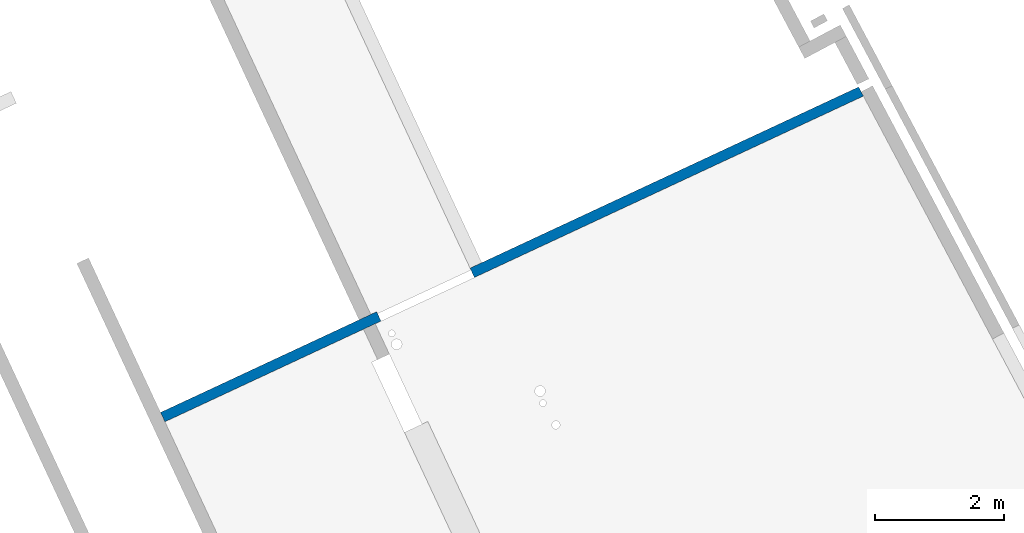
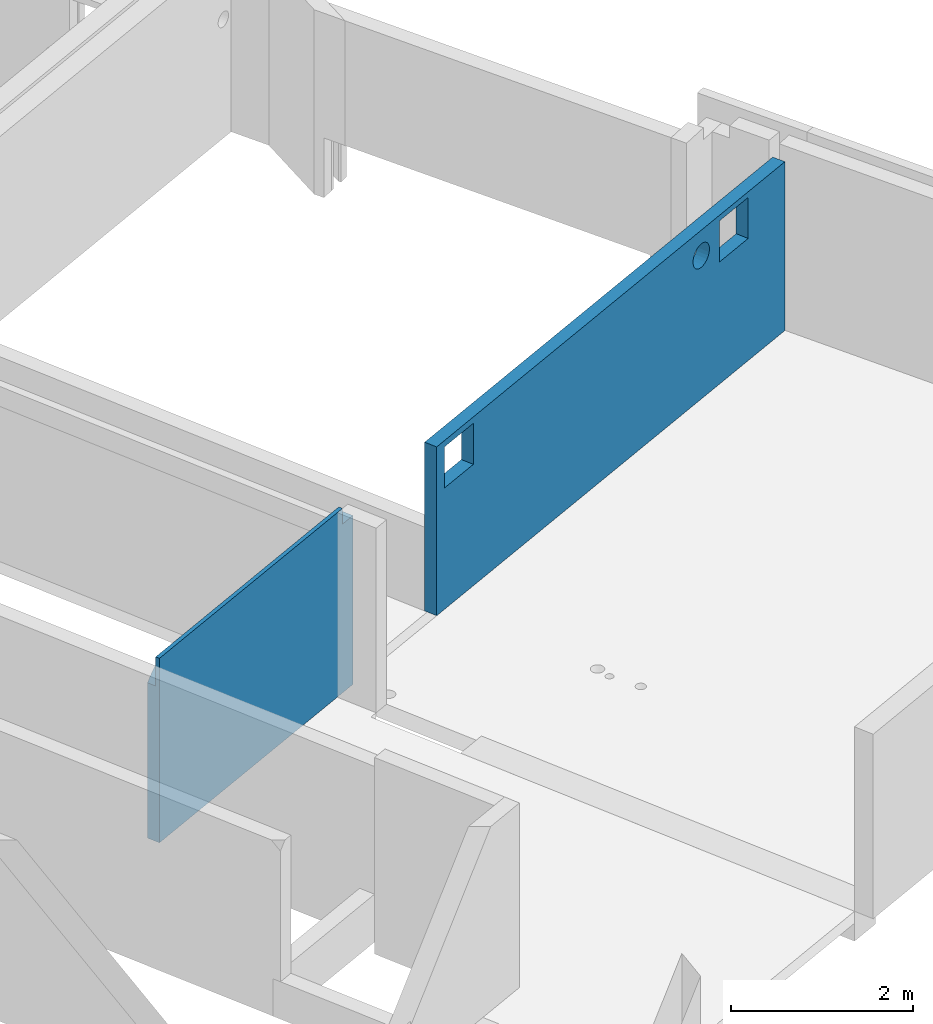
# One storey, part 8 of 13: 1 wall.
"""IFC2X3 building model written with IfcOpenShell, lengths in metres."""

from ifc_helpers import new_model, entity, si_unit, converted_unit, derived_unit, direction, frame, origin, place, context, subcontext, project, spatial, faceted_brep, material, layer, layer_set, type_object, element, save


model = new_model("IFC2X3")

# Units and contexts
model_context = context("Model", 3, precision=1e-05, world=origin(), true_north=direction((6.12303176911189e-17, 1.0)))
body_context = subcontext(model_context, "Body", "Model", "MODEL_VIEW")
ifc_project = project(units=[si_unit("LENGTHUNIT", "METRE"), si_unit("AREAUNIT", "SQUARE_METRE"), si_unit("VOLUMEUNIT", "CUBIC_METRE"), converted_unit("PLANEANGLEUNIT", "DEGREE", entity("IfcRatioMeasure", 0.0174532925199433), si_unit("PLANEANGLEUNIT", "RADIAN"), dimensions=[0, 0, 0, 0, 0, 0, 0]), si_unit("MASSUNIT", "GRAM", prefix="KILO"), derived_unit("MASSDENSITYUNIT", [(si_unit("MASSUNIT", "GRAM", prefix="KILO"), 1), (si_unit("LENGTHUNIT", "METRE"), -3)]), si_unit("TIMEUNIT", "SECOND"), si_unit("FREQUENCYUNIT", "HERTZ"), si_unit("THERMODYNAMICTEMPERATUREUNIT", "DEGREE_CELSIUS"), derived_unit("THERMALTRANSMITTANCEUNIT", [(si_unit("MASSUNIT", "GRAM", prefix="KILO"), 1), (si_unit("THERMODYNAMICTEMPERATUREUNIT", "KELVIN"), -1), (si_unit("TIMEUNIT", "SECOND"), -3)]), derived_unit("VOLUMETRICFLOWRATEUNIT", [(si_unit("LENGTHUNIT", "METRE"), 3), (si_unit("TIMEUNIT", "SECOND"), -1)]), si_unit("ELECTRICCURRENTUNIT", "AMPERE"), si_unit("ELECTRICVOLTAGEUNIT", "VOLT"), si_unit("POWERUNIT", "WATT"), si_unit("FORCEUNIT", "NEWTON", prefix="KILO"), si_unit("ILLUMINANCEUNIT", "LUX"), si_unit("LUMINOUSFLUXUNIT", "LUMEN"), si_unit("LUMINOUSINTENSITYUNIT", "CANDELA"), derived_unit("USERDEFINED", [(si_unit("MASSUNIT", "GRAM", prefix="KILO"), -1), (si_unit("LENGTHUNIT", "METRE"), -2), (si_unit("TIMEUNIT", "SECOND"), 3), (si_unit("LUMINOUSFLUXUNIT", "LUMEN"), 1)]), derived_unit("LINEARVELOCITYUNIT", [(si_unit("LENGTHUNIT", "METRE"), 1), (si_unit("TIMEUNIT", "SECOND"), -1)]), si_unit("PRESSUREUNIT", "PASCAL"), derived_unit("USERDEFINED", [(si_unit("LENGTHUNIT", "METRE"), -2), (si_unit("MASSUNIT", "GRAM", prefix="KILO"), 1), (si_unit("TIMEUNIT", "SECOND"), -2)])], contexts=[model_context])

# Site, building, storey
site_placement = place(None, frame((5.36960000000003, 43.3158000000006, 0.0), z_axis=(0.0, 0.0, 1.0), x_axis=(-0.422618261740703, 0.906307787036648, 0.0)))
site = spatial("IfcSite", under=ifc_project, at=site_placement, CompositionType="ELEMENT")
building_placement = place(site_placement, origin())
building = spatial("IfcBuilding", under=site, at=building_placement, CompositionType="ELEMENT")
storey_placement = place(building_placement, frame((0.0, 0.0, 2.56)))
storey = spatial("IfcBuildingStorey", under=building, at=storey_placement, CompositionType="ELEMENT", Elevation=2.56)

# Wall
ifc_material = material(Name="C30/37 XC1")
ifc_layer = layer(ifc_material, 0.16)
ifc_layer_set = layer_set([ifc_layer])
wall_type = type_object("IfcWallType", PredefinedType="NOTDEFINED", material=ifc_layer_set)
wall_placement = place(storey_placement, frame((13.0006608482375, 13.1325037603587, 0.0), z_axis=(0.0, 0.0, 1.0), x_axis=(0.0, -1.0, 0.0)))
element("IfcWall", 1, at=wall_placement, inside=storey, type_object=wall_type, Name="XS1", context=body_context, shape_type="Brep", body=[
    faceted_brep([(0.0, 0.0799999999999993, 0.0), (3.69997791133383, 0.0799999999999983, 0.0), (3.69997791133383, -0.0800000000000022, 0.0), (0.0, -0.0799999999999989, 0.0), (0.0, 0.0799999999999993, 2.07800573622916), (0.0540647674175499, 0.0799999999999998, 2.14298123226232), (0.116506424114537, 0.0800000000000003, 2.19995362618784), (0.186151946035246, 0.0800000000000008, 2.24785263909063), (0.261692977877982, 0.0799999999999992, 2.28577844387845), (0.341710411754961, 0.0799999999999999, 2.31301856936297), (0.424701046441563, 0.0800000000000005, 2.32906128468751), (0.509105826396406, 0.079999999999999, 2.3336052126627), (0.593339130056231, 0.0799999999999997, 2.32656499141468), (0.67581855719798, 0.0800000000000004, 2.30807287798657), (0.754994655785037, 0.080000000000001, 2.27847626376802), (0.829380029851418, 0.0799999999999994, 2.23833114842788), (0.897577281605511, 0.0799999999999999, 2.1883916949481), (0.958305262835159, 0.0800000000000004, 2.12959606197727), (1.01042314245731, 0.0800000000000008, 2.0630487796559), (1.05295183808109, 0.079999999999999, 1.99000000000005), (1.14700398459006, 0.0799999999999998, 1.99000000000006), (1.19017387657793, 0.0800000000000001, 2.06399261157951), (1.24318059167475, 0.0800000000000005, 2.13128922588688), (1.30500134927377, 0.080000000000001, 2.19059133438627), (1.37444329915118, 0.0799999999999994, 2.24075468495036), (1.4501665378721, 0.08, 2.28081136055138), (1.5307099626328, 0.0800000000000006, 2.30998845551315), (1.61451946368142, 0.0799999999999991, 2.32772298895986), (1.69997791133585, 0.0799999999999998, 2.33367276770247), (1.78543635899028, 0.0800000000000005, 2.32772298895985), (1.8692458600389, 0.079999999999999, 2.30998845551314), (1.9497892847996, 0.0799999999999996, 2.28081136055138), (2.02551252352052, 0.0800000000000002, 2.24075468495035), (2.09495447339793, 0.0800000000000007, 2.19059133438626), (2.15677523099694, 0.0799999999999991, 2.13128922588687), (2.20978194609376, 0.0799999999999995, 2.06399261157949), (2.25295183808165, 0.0799999999999998, 1.99000000000006), (2.3470039845898, 0.0800000000000006, 1.99000000000006), (2.39017387657767, 0.0800000000000009, 2.06399261157951), (2.4431805916745, 0.0799999999999992, 2.13128922588688), (2.50500134927352, 0.0799999999999996, 2.19059133438628), (2.57444329915092, 0.0800000000000002, 2.24075468495036), (2.65016653787184, 0.0800000000000008, 2.28081136055139), (2.73070996263254, 0.0799999999999993, 2.30998845551315), (2.81451946368116, 0.0799999999999999, 2.32772298895986), (2.8999779113356, 0.0800000000000006, 2.33367276770248), (2.98543635899002, 0.0799999999999991, 2.32772298895986), (3.06924586003864, 0.0799999999999998, 2.30998845551315), (3.14978928479935, 0.0800000000000004, 2.28081136055138), (3.22551252352026, 0.080000000000001, 2.24075468495035), (3.29495447339767, 0.0799999999999994, 2.19059133438627), (3.35677523099669, 0.0799999999999999, 2.13128922588687), (3.40978194609351, 0.0800000000000003, 2.0639926115795), (3.4529518380814, 0.0800000000000006, 1.99000000000006), (3.49997791133412, 0.080000000000001, 1.99000000000006), (3.49997791133412, 0.080000000000001, 2.26), (3.59997791133629, 0.0799999999999996, 2.26), (3.69997791133383, 0.0800000000000004, 2.26), (3.39997791133411, -0.0800000000000002, 2.47), (0.0, -0.0800000000000011, 2.47), (0.0, -0.0800000000000011, 2.26), (3.69997791133383, -0.08, 2.26), (3.59997791133411, -0.0800000000000008, 2.26), (3.49997791133869, -0.0799999999999994, 2.26), (3.49997791133869, -0.0799999999999994, 2.47), (3.49997791133412, -0.0300000000002209, 2.47), (0.0, -0.0300000000002139, 2.47), (0.0, -0.0300000000002139, 2.07800573622919), (0.509102556304195, -0.0300000000002164, 2.33360526106011), (0.42469795081063, -0.0300000000002149, 2.3290609039723), (0.341707651595475, -0.0300000000002155, 2.31301783646269), (0.261690685984044, -0.0300000000002161, 2.28577748376197), (0.186150215713108, -0.0300000000002146, 2.24785161623326), (0.116505300126185, -0.0300000000002151, 2.1999527337884), (0.0540642395365872, -0.0300000000002156, 2.14298067972582), (3.49997791133412, -0.0300000000002209, 2.26), (3.49997791133412, -0.0300000000002209, 1.99000000000006), (3.4529518380814, -0.0300000000002213, 1.99000000000006), (3.40978194609353, -0.0300000000002216, 2.06399261157951), (3.35677523099671, -0.030000000000222, 2.13128922588688), (3.29495447339769, -0.0300000000002203, 2.19059133438628), (3.22551252352028, -0.0300000000002209, 2.24075468495036), (3.14978928479936, -0.0300000000002215, 2.28081136055139), (3.06924586003866, -0.03000000000022, 2.30998845551315), (2.98543635899004, -0.0300000000002206, 2.32772298895986), (2.89997791133561, -0.0300000000002213, 2.33367276770248), (2.81451946368118, -0.0300000000002198, 2.32772298895986), (2.73070996263256, -0.0300000000002205, 2.30998845551315), (2.65016653787186, -0.0300000000002211, 2.28081136055138), (2.57444329915094, -0.0300000000002195, 2.24075468495035), (2.50500134927354, -0.0300000000002201, 2.19059133438627), (2.44318059167451, -0.0300000000002206, 2.13128922588688), (2.39017387657769, -0.0300000000002188, 2.0639926115795), (2.34700398458983, -0.0300000000002192, 1.99000000000006), (2.25295183808165, -0.0300000000002199, 1.99000000000006), (2.20978194609378, -0.0300000000002202, 2.0639926115795), (2.15677523099696, -0.0300000000002185, 2.13128922588688), (2.09495447339794, -0.030000000000219, 2.19059133438627), (2.02551252352054, -0.0300000000002195, 2.24075468495035), (1.94978928479962, -0.030000000000218, 2.28081136055138), (1.86924586003891, -0.0300000000002186, 2.30998845551315), (1.7854363589903, -0.0300000000002193, 2.32772298895986), (1.69997791133587, -0.0300000000002178, 2.33367276770247), (1.61451946368143, -0.0300000000002184, 2.32772298895985), (1.53070996263282, -0.0300000000002169, 2.30998845551315), (1.45016653787211, -0.0300000000002176, 2.28081136055138), (1.3744432991512, -0.0300000000002182, 2.24075468495035), (1.30500134927379, -0.0300000000002166, 2.19059133438627), (1.24318059167477, -0.0300000000002171, 2.13128922588687), (1.19017387657795, -0.0300000000002175, 2.0639926115795), (1.14700398459008, -0.0300000000002178, 1.99000000000005), (1.05295183808109, -0.0300000000002164, 1.99000000000005), (1.01042260784432, -0.0300000000002167, 2.06304956816565), (0.958304179887242, -0.0300000000002171, 2.12959726485254), (0.897575586120023, -0.0300000000002176, 2.18839312490938), (0.829377761928949, -0.030000000000216, 2.23833258130818), (0.754991909372078, -0.0300000000002166, 2.27847751107533), (0.675815467961812, -0.0300000000002172, 2.3080737969531), (0.593335861735365, -0.0300000000002157, 2.32656549195455)], [[[0, 1, 2, 3]], [[1, 0, 4, 5, 6, 7, 8, 9, 10, 11, 12, 13, 14, 15, 16, 17, 18, 19, 20, 21, 22, 23, 24, 25, 26, 27, 28, 29, 30, 31, 32, 33, 34, 35, 36, 37, 38, 39, 40, 41, 42, 43, 44, 45, 46, 47, 48, 49, 50, 51, 52, 53, 54, 55, 56, 57]], [[58, 59, 60, 3, 2, 61, 62, 63, 64]], [[58, 64, 65, 66, 59]], [[67, 4, 0, 3, 60, 59, 66]], [[68, 69, 70, 71, 72, 73, 74, 67, 66, 65, 75, 76, 77, 78, 79, 80, 81, 82, 83, 84, 85, 86, 87, 88, 89, 90, 91, 92, 93, 94, 95, 96, 97, 98, 99, 100, 101, 102, 103, 104, 105, 106, 107, 108, 109, 110, 111, 112, 113, 114, 115, 116, 117, 118]], [[76, 75, 55, 54]], [[74, 73, 5]], [[74, 4, 67]], [[72, 6, 73]], [[8, 71, 70]], [[9, 70, 69]], [[7, 72, 71]], [[68, 10, 69]], [[7, 6, 72]], [[5, 4, 74]], [[6, 5, 73]], [[9, 8, 70]], [[11, 10, 68]], [[9, 69, 10]], [[7, 71, 8]], [[68, 118, 11]], [[12, 118, 117]], [[13, 117, 116]], [[115, 14, 116]], [[16, 114, 113]], [[113, 112, 17]], [[114, 15, 115]], [[18, 112, 111]], [[13, 12, 117]], [[15, 14, 115]], [[13, 116, 14]], [[17, 16, 113]], [[19, 18, 111]], [[17, 112, 18]], [[15, 114, 16]], [[118, 12, 11]], [[20, 19, 111, 110]], [[37, 36, 94, 93]], [[54, 53, 77, 76]], [[23, 22, 108, 107]], [[108, 22, 21, 109]], [[106, 24, 23, 107]], [[104, 26, 25, 105]], [[26, 104, 103, 27]], [[25, 24, 106, 105]], [[102, 28, 27, 103]], [[109, 21, 20, 110]], [[29, 101, 100, 30]], [[30, 100, 99, 31]], [[98, 32, 31, 99]], [[33, 97, 96, 34]], [[96, 95, 35, 34]], [[97, 33, 32, 98]], [[35, 95, 94, 36]], [[29, 28, 102, 101]], [[40, 39, 91, 90]], [[91, 39, 38, 92]], [[89, 41, 40, 90]], [[87, 43, 42, 88]], [[43, 87, 86, 44]], [[42, 41, 89, 88]], [[85, 45, 44, 86]], [[92, 38, 37, 93]], [[46, 84, 83, 47]], [[47, 83, 82, 48]], [[81, 49, 48, 82]], [[50, 80, 79, 51]], [[79, 78, 52, 51]], [[80, 50, 49, 81]], [[52, 78, 77, 53]], [[46, 45, 85, 84]], [[75, 63, 62, 61, 57, 56, 55]], [[65, 64, 63, 75]], [[57, 61, 2, 1]]]),
    faceted_brep([(11.9530510296318, 0.0799999999999985, 2.26), (5.29997791133383, 0.0800000000000001, 2.26), (5.29997791133383, -0.0800000000000004, 2.26), (11.9614016144943, -0.0799999999999954, 2.26), (5.29997791133383, -0.0800000000000004, 0.0), (6.00165913325264, -0.0800000000000013, 1.6249998993897), (5.45165913325264, -0.0800000000000013, 1.6249998993897), (10.2476644481492, -0.0800000000000003, 1.80863068196312), (10.280283766186, -0.08, 1.78360099890395), (11.9614016144943, -0.0799999999999997, 0.0), (10.3182697665824, -0.0799999999999997, 1.76786668235947), (10.7056146308703, -0.080000000000001, 1.63500050947051), (11.2556146308703, -0.080000000000001, 1.63500050947051), (10.7056146308703, -0.080000000000001, 2.18500050947051), (11.2556146308703, -0.080000000000001, 2.18500050947051), (10.359033766186, -0.0800000000000016, 1.7625), (10.516533766186, -0.0800000000000003, 1.92), (10.5111670838266, -0.0800000000000004, 1.87923600039635), (10.4954327672821, -0.0800000000000005, 1.84125), (10.4704030842229, -0.0800000000000007, 1.80863068196311), (10.437783766186, -0.0800000000000009, 1.78360099890395), (10.3997977657897, -0.0800000000000012, 1.76786668235947), (10.22263476509, -0.0800000000000005, 1.84125), (10.2069004485455, -0.0800000000000006, 1.87923600039635), (10.201533766186, -0.0800000000000006, 1.92), (6.00165913325264, -0.0800000000000013, 2.1749998993897), (10.2069004485455, -0.0800000000000006, 1.96076399960364), (10.22263476509, -0.0800000000000005, 1.99875), (10.2476644481492, -0.0800000000000003, 2.03136931803688), (10.280283766186, -0.08, 2.05639900109605), (10.3182697665824, -0.0799999999999997, 2.07213331764053), (10.359033766186, -0.0800000000000016, 2.0775), (10.3997977657897, -0.0800000000000012, 2.07213331764052), (10.437783766186, -0.0800000000000009, 2.05639900109605), (10.4704030842229, -0.0800000000000007, 2.03136931803688), (10.4954327672821, -0.0800000000000005, 1.99875), (10.5111670838266, -0.0800000000000004, 1.96076399960364), (5.45165913325264, -0.0800000000000013, 2.1749998993897), (11.9530510296318, 0.0800000000000006, 0.0), (10.7056146308703, 0.0799999999999995, 1.63500050947051), (11.2556146308703, 0.0799999999999995, 1.63500050947051), (10.3182697665824, 0.0800000000000007, 1.76786668235947), (10.280283766186, 0.0800000000000004, 1.78360099890395), (5.29997791133383, 0.0800000000000001, 0.0), (10.2476644481492, 0.0800000000000002, 1.80863068196312), (6.00165913325264, 0.0799999999999991, 1.6249998993897), (5.29997791133383, 0.0800000000000001, 1.12), (5.45165913325264, 0.0799999999999991, 1.6249998993897), (10.7056146308703, 0.0799999999999995, 2.18500050947051), (5.45165913325264, 0.0799999999999991, 2.1749998993897), (6.00165913325264, 0.0799999999999991, 2.1749998993897), (10.201533766186, 0.0799999999999998, 1.92), (10.2069004485455, 0.0799999999999998, 1.96076399960364), (10.22263476509, 0.08, 1.99875), (10.2476644481492, 0.0800000000000002, 2.03136931803688), (10.280283766186, 0.0800000000000004, 2.05639900109605), (10.3182697665824, 0.0800000000000007, 2.07213331764053), (10.359033766186, 0.0799999999999989, 2.0775), (10.2069004485455, 0.0799999999999998, 1.87923600039635), (10.22263476509, 0.08, 1.84125), (10.359033766186, 0.0799999999999989, 1.7625), (10.3997977657897, 0.0799999999999992, 1.76786668235947), (10.437783766186, 0.0799999999999995, 1.78360099890395), (10.4704030842229, 0.0799999999999998, 1.80863068196311), (10.4954327672821, 0.08, 1.84125), (10.5111670838266, 0.0800000000000001, 1.87923600039635), (10.516533766186, 0.0800000000000001, 1.92), (10.5111670838266, 0.0800000000000001, 1.96076399960364), (10.4954327672821, 0.08, 1.99875), (10.4704030842229, 0.0799999999999998, 2.03136931803688), (10.437783766186, 0.0799999999999995, 2.05639900109605), (10.3997977657897, 0.0799999999999992, 2.07213331764052), (11.2556146308703, 0.0799999999999995, 2.18500050947051)], [[[0, 1, 2, 3]], [[4, 5, 6]], [[5, 4, 7]], [[4, 6, 2]], [[8, 7, 4]], [[9, 8, 4]], [[9, 10, 8]], [[10, 9, 11]], [[11, 9, 12]], [[9, 3, 12]], [[13, 3, 2]], [[13, 14, 3]], [[12, 3, 14]], [[11, 15, 10]], [[13, 16, 11]], [[11, 16, 17]], [[11, 17, 18]], [[18, 19, 11]], [[20, 11, 19]], [[20, 21, 11]], [[21, 15, 11]], [[7, 22, 5]], [[23, 5, 22]], [[24, 5, 23]], [[25, 5, 24]], [[25, 24, 26]], [[26, 27, 25]], [[27, 28, 25]], [[28, 29, 25]], [[29, 30, 25]], [[13, 25, 30]], [[31, 13, 30]], [[31, 32, 13]], [[33, 13, 32]], [[33, 34, 13]], [[35, 13, 34]], [[35, 36, 13]], [[13, 36, 16]], [[13, 2, 25]], [[2, 37, 25]], [[37, 2, 6]], [[38, 39, 40]], [[38, 40, 0]], [[39, 38, 41]], [[38, 42, 41]], [[43, 42, 38]], [[44, 42, 43]], [[45, 44, 43]], [[43, 46, 45]], [[47, 45, 46]], [[46, 1, 47]], [[48, 1, 0]], [[1, 49, 47]], [[50, 49, 1]], [[48, 50, 1]], [[51, 45, 50]], [[50, 52, 51]], [[53, 52, 50]], [[53, 50, 54]], [[55, 54, 50]], [[56, 55, 50]], [[50, 48, 56]], [[48, 57, 56]], [[58, 45, 51]], [[58, 59, 45]], [[59, 44, 45]], [[60, 39, 41]], [[61, 39, 60]], [[61, 62, 39]], [[62, 63, 39]], [[63, 64, 39]], [[64, 65, 39]], [[39, 65, 66]], [[48, 39, 66]], [[66, 67, 48]], [[48, 67, 68]], [[68, 69, 48]], [[69, 70, 48]], [[70, 71, 48]], [[71, 57, 48]], [[0, 40, 72]], [[0, 72, 48]], [[46, 43, 4, 2, 1]], [[9, 38, 0, 3]], [[37, 6, 47, 49]], [[25, 37, 49, 50]], [[5, 25, 50, 45]], [[6, 5, 45, 47]], [[58, 51, 24, 23]], [[58, 23, 22, 59]], [[42, 44, 7, 8]], [[7, 44, 59, 22]], [[41, 42, 8, 10]], [[10, 15, 60, 41]], [[62, 61, 21, 20]], [[62, 20, 19, 63]], [[65, 64, 18, 17]], [[18, 64, 63, 19]], [[66, 65, 17, 16]], [[60, 15, 21, 61]], [[67, 66, 16, 36]], [[67, 36, 35, 68]], [[70, 69, 34, 33]], [[71, 70, 33, 32]], [[69, 68, 35, 34]], [[32, 31, 57, 71]], [[55, 56, 30, 29]], [[55, 29, 28, 54]], [[52, 53, 27, 26]], [[27, 53, 54, 28]], [[51, 52, 26, 24]], [[57, 31, 30, 56]], [[13, 11, 39, 48]], [[14, 13, 48, 72]], [[12, 14, 72, 40]], [[11, 12, 40, 39]], [[43, 38, 9, 4]]]),
])

save(model, "model.ifc")
